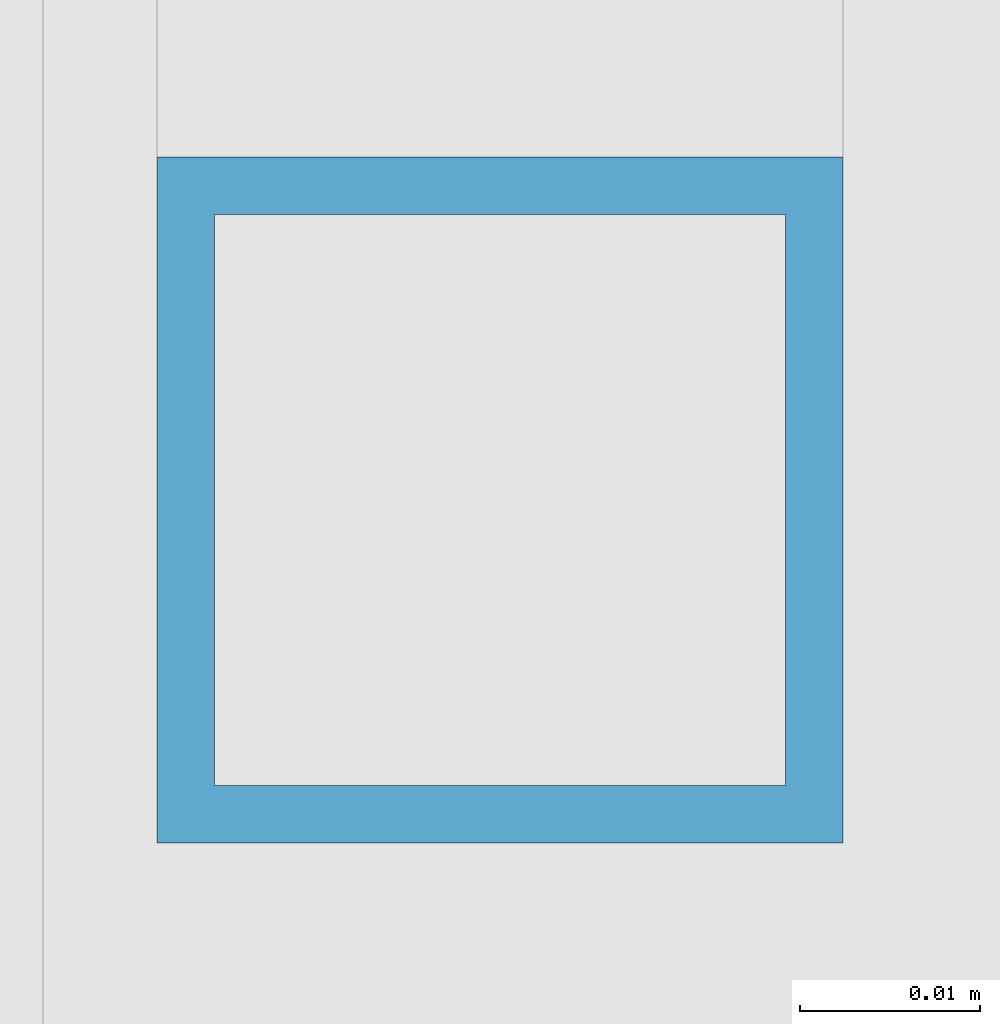
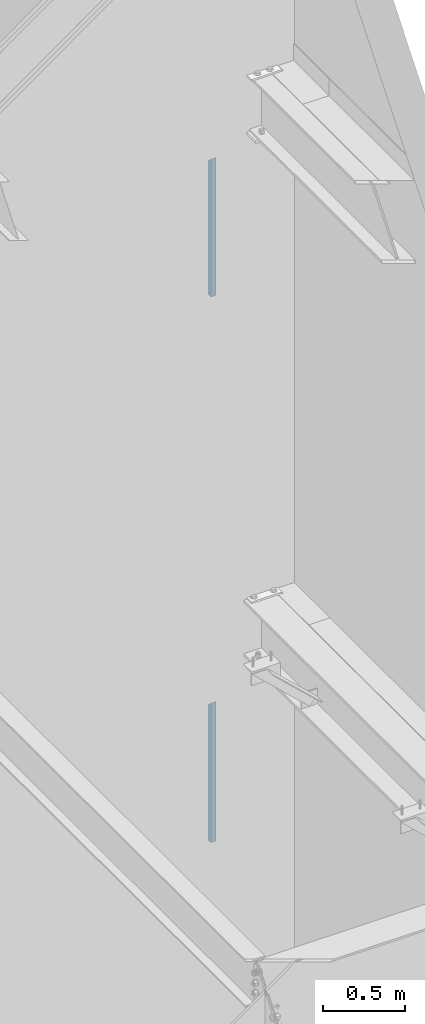
# One storey, part 373 of 1179: 2 columns, 2 elements without a shape of their own.
"""IFC2X3 building model written with IfcOpenShell, lengths in millimetres."""

from ifc_helpers import new_model, si_unit, frame, origin_with_axes, place, context, subcontext, project, spatial, faceted_brep, material, type_object, element, aggregate, save


model = new_model("IFC2X3")

# Units and contexts
model_context = context("Model", 3, precision=1e-05, world=origin_with_axes())
body_context = subcontext(model_context, "Body", "Model", "MODEL_VIEW")
ifc_project = project(units=[si_unit("LENGTHUNIT", "METRE", prefix="MILLI"), si_unit("AREAUNIT", "SQUARE_METRE"), si_unit("VOLUMEUNIT", "CUBIC_METRE"), si_unit("MASSUNIT", "GRAM", prefix="KILO"), si_unit("TIMEUNIT", "SECOND"), si_unit("PLANEANGLEUNIT", "RADIAN"), si_unit("SOLIDANGLEUNIT", "STERADIAN"), si_unit("THERMODYNAMICTEMPERATUREUNIT", "DEGREE_CELSIUS"), si_unit("LUMINOUSINTENSITYUNIT", "LUMEN")], contexts=[model_context])

# Site, building, storey
site_placement = place(None, origin_with_axes())
site = spatial("IfcSite", under=ifc_project, at=site_placement, CompositionType="ELEMENT")
building_placement = place(site_placement, origin_with_axes())
building = spatial("IfcBuilding", under=site, at=building_placement, Name="Undefined", CompositionType="ELEMENT")
storey_placement = place(building_placement, origin_with_axes())
storey = spatial("IfcBuildingStorey", under=building, at=storey_placement, Name="Undefined", CompositionType="ELEMENT", Elevation=0.0)

# Assembly, column
assembly_1_placement = place(storey_placement, origin_with_axes())
assembly_1 = element("IfcElementAssembly", 1, at=assembly_1_placement, inside=storey, Name="GUARDRAIL", AssemblyPlace="NOTDEFINED", PredefinedType="RIGID_FRAME")
ifc_material = material()
column_type = type_object("IfcColumnType", Name="HSS1-1/2X1-1/2X1/8", PredefinedType="NOTDEFINED")
column_1_placement = place(assembly_1_placement, frame((24114.1250004143, 38157.150000001, 6242.05), z_axis=(-1.0, 0.0, 0.0), x_axis=(0.0, 0.0, 1.0)))
column_1 = element("IfcColumn", 2, at=column_1_placement, type_object=column_type, material=ifc_material, Name="POST", ObjectType="HSS1-1/2X1-1/2X1/8", context=body_context, shape_type="Brep", body=[
    faceted_brep([(0.0, 15.8749992830017, -15.8749992829999), (0.0, -15.8749992830017, -15.8749992829999), (1031.87499843655, -15.874999282998, -15.8749992830017), (1000.12499987055, 15.874999282998, -15.8749992830017), (0.0, -15.8749992830017, 15.8749992829999), (1031.87499843655, -15.874999282998, 15.8749992830017), (0.0, 15.8749992830017, 15.8749992829999), (1000.12499987055, 15.874999282998, 15.8749992830017), (0.0, 19.0499992350015, -19.0499992349996), (0.0, 19.0499992350015, 19.0499992349996), (996.949999918551, 19.0499992350015, 19.0499992350015), (996.949999918551, 19.0499992350015, -19.0499992350015), (0.0, -19.0499992350015, 19.0499992349996), (1035.05, -19.050000003459, 19.0499992350015), (0.0, -19.0499992350015, -19.0499992349996), (1035.05, -19.0499992350015, -19.0499992350015)], [[[0, 1, 2, 3]], [[1, 4, 5, 2]], [[4, 6, 7, 5]], [[6, 0, 3, 7]], [[8, 9, 10, 11]], [[9, 12, 13, 10]], [[12, 14, 15, 13]], [[14, 8, 11, 15]], [[13, 15, 11, 10], [5, 7, 3, 2]], [[14, 12, 9, 8], [6, 4, 1, 0]]]),
])
aggregate(assembly_1, [column_1])

assembly_2_placement = place(storey_placement, origin_with_axes())
assembly_2 = element("IfcElementAssembly", 3, at=assembly_2_placement, inside=storey, Name="GUARDRAIL", AssemblyPlace="NOTDEFINED", PredefinedType="RIGID_FRAME")
column_2_placement = place(assembly_2_placement, frame((24114.1250004143, 38157.150000001, 2155.825), z_axis=(-1.0, 0.0, 0.0), x_axis=(0.0, 0.0, 1.0)))
column_2 = element("IfcColumn", 4, at=column_2_placement, type_object=column_type, material=ifc_material, Name="POST", ObjectType="HSS1-1/2X1-1/2X1/8", context=body_context, shape_type="Brep", body=[
    faceted_brep([(0.0, 15.8749992830017, -15.8749992829999), (0.0, -15.8749992830017, -15.8749992829999), (1044.57499843655, -15.874999282998, -15.8749992830017), (1012.82499987055, 15.874999282998, -15.8749992830017), (0.0, -15.8749992830017, 15.8749992829999), (1044.57499843655, -15.874999282998, 15.8749992830017), (0.0, 15.8749992830017, 15.8749992829999), (1012.82499987055, 15.874999282998, 15.8749992830017), (0.0, 19.0499992350015, -19.0499992349996), (0.0, 19.0499992350015, 19.0499992349996), (1009.64999991855, 19.0499992350015, 19.0499992350015), (1009.64999991855, 19.0499992350015, -19.0499992350015), (0.0, -19.0499992350015, 19.0499992349996), (1047.74999838855, -19.0499992350015, 19.0499992350015), (0.0, -19.0499992350015, -19.0499992349996), (1047.74999838855, -19.0499992350015, -19.0499992350015)], [[[0, 1, 2, 3]], [[1, 4, 5, 2]], [[4, 6, 7, 5]], [[6, 0, 3, 7]], [[8, 9, 10, 11]], [[9, 12, 13, 10]], [[12, 14, 15, 13]], [[14, 8, 11, 15]], [[13, 15, 11, 10], [5, 7, 3, 2]], [[14, 12, 9, 8], [6, 4, 1, 0]]]),
])
aggregate(assembly_2, [column_2])

save(model, "model.ifc")
